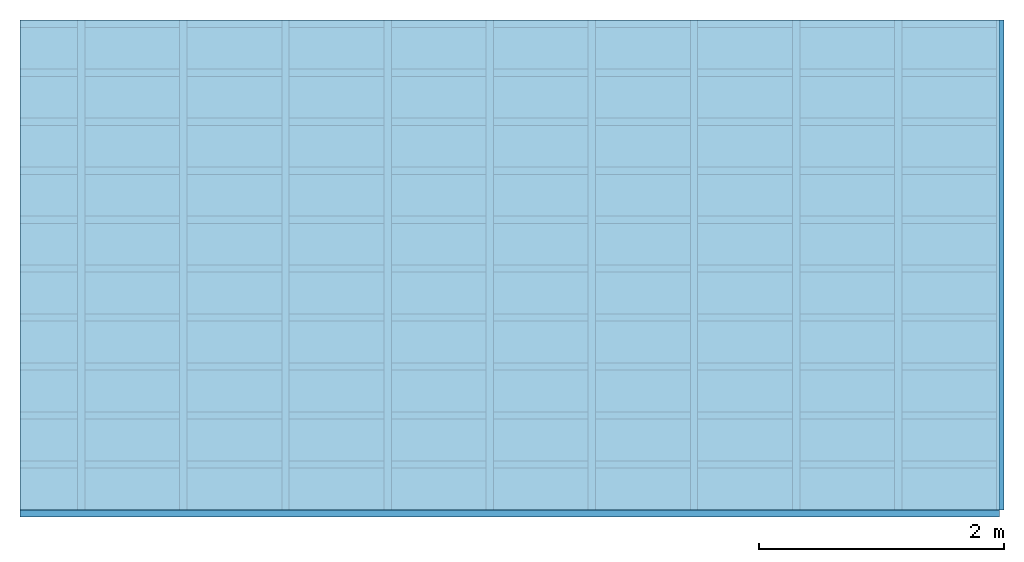
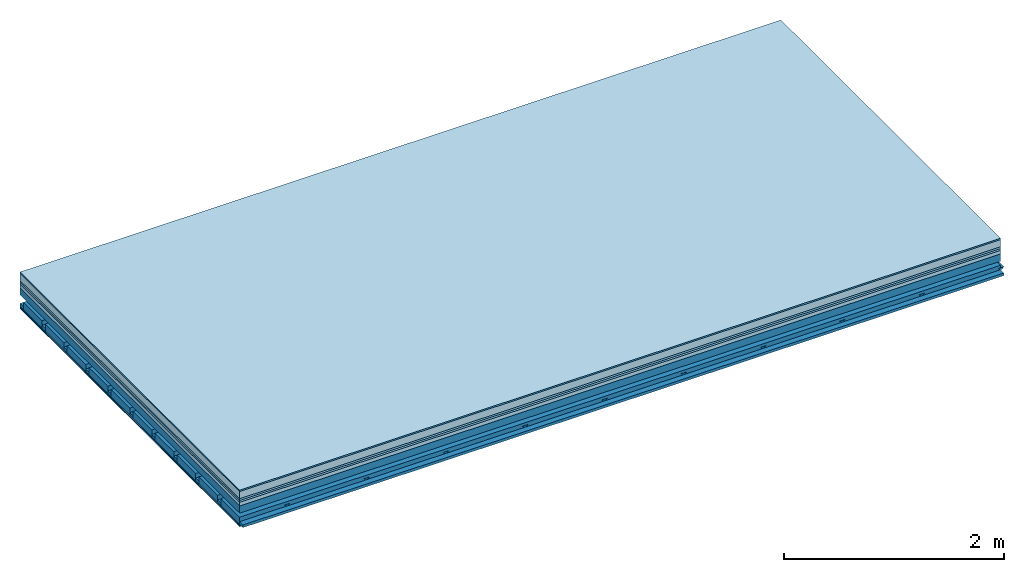
# One storey: 8 plates, 4 members, 1 element without a shape of its own.
"""IFC4 building model written with IfcOpenShell, lengths in metres."""

from ifc_helpers import new_model, si_unit, derived_unit, direction, frame, frame_2d, origin, origin_with_axes, place, context, project, spatial, polyline, rectangle, outline, extrude, material, layer, layer_set, type_object, element, aggregate, save


model = new_model("IFC4")

# Units and contexts
plan_context = context("Plan", 3, precision=1e-05, world=origin(), true_north=direction((0.0, 1.0)))
model_context = context("Model", 3, precision=1e-05, world=origin(), true_north=direction((0.0, 1.0)))
ifc_project = project(units=[si_unit("LENGTHUNIT", "METRE"), derived_unit("SOUNDPRESSUREUNIT", [(si_unit("PRESSUREUNIT", "PASCAL", prefix="MICRO"), 0)]), si_unit("ENERGYUNIT", "JOULE", prefix="MEGA"), si_unit("MASSUNIT", "GRAM", prefix="KILO"), derived_unit("THERMALTRANSMITTANCEUNIT", [(si_unit("POWERUNIT", "WATT"), 1), (si_unit("AREAUNIT", "SQUARE_METRE"), -1), (si_unit("THERMODYNAMICTEMPERATUREUNIT", "KELVIN"), -1)]), derived_unit("AREADENSITYUNIT", [(si_unit("MASSUNIT", "GRAM", prefix="KILO"), 1), (si_unit("AREAUNIT", "SQUARE_METRE"), -1)]), derived_unit("USERDEFINED", [(si_unit("ENERGYUNIT", "JOULE", prefix="MEGA"), 1), (si_unit("AREAUNIT", "SQUARE_METRE"), -1)])], contexts=[plan_context, model_context])

# Site, building, storey
site = spatial("IfcSite", under=ifc_project)
building_placement = place(None, origin())
building = spatial("IfcBuilding", under=site, at=building_placement)
storey_placement = place(building_placement, origin())
storey = spatial("IfcBuildingStorey", under=building, at=storey_placement)

# Slab, members, plates
ifc_material_1 = material(Category="11.013")
ifc_layer_1 = layer(ifc_material_1, 0.015, Name="Flooring")
ifc_material_2 = material(Name="Cement screed", Category="04.006")
ifc_layer_2 = layer(ifc_material_2, 0.08, Name="On-material")
ifc_material_3 = material(Name="Wood fiber generic product", Category="10.009")
ifc_layer_3 = layer(ifc_material_3, 0.02, Name="Impact sound insulation")
ifc_material_4 = material(Category="10.004")
ifc_layer_4 = layer(ifc_material_4, 0.02, Name="Additional insulation")
ifc_material_5 = material(Name="Garden plates", Category="02.007")
ifc_layer_5 = layer(ifc_material_5, 0.04, Name="on Supporting structure")
ifc_material_6 = material(Name="no composite action")
ifc_layer_6 = layer(ifc_material_6, 0.0, Name="Bond")
ifc_layer_7 = layer(None, 0.08, Name="Supporting structure")
ifc_layer_8 = layer(ifc_material_6, 0.0, Name="Bond")
ifc_layer_9 = layer(None, 0.095, Name="Coupling")
ifc_layer_10 = layer(None, 0.03, Name="Battens / profiles")
ifc_material_7 = material(Name="Plasterboard type A", Category="03.008")
ifc_layer_11 = layer(ifc_material_7, 0.0125, Name="Ceiling covering 1st layer")
ifc_layer_12 = layer(ifc_material_7, 0.0125, Name="Ceiling covering layer 2")
ifc_material_8 = material(Category="04.001")
ifc_layer_13 = layer(ifc_material_8, 0.003, Name="Surface / treatment")
ifc_layer_set = layer_set([ifc_layer_1, ifc_layer_2, ifc_layer_3, ifc_layer_4, ifc_layer_5, ifc_layer_6, ifc_layer_7, ifc_layer_8, ifc_layer_9, ifc_layer_10, ifc_layer_11, ifc_layer_12, ifc_layer_13])
slab_type = type_object("IfcSlabType", Name="A2166", PredefinedType="NOTDEFINED", material=ifc_layer_set)
slab_placement = place(None, frame((0.0, 0.0, 0.0), z_axis=(0.0, 0.0, -1.0), x_axis=(1.0, 0.0, 0.0)))
slab = element("IfcSlab", 1, at=slab_placement, inside=storey, type_object=slab_type, material=ifc_layer_set, Name="Slab #1")
ifc_material_9 = material(Name="Solid timber panel")
member_1_placement = place(slab_placement, origin())
member_1 = element("IfcMember", 2, at=member_1_placement, material=ifc_material_9, Name="Supporting structure", context=plan_context, shape_type="SweptSolid", body=[
    extrude(rectangle(XDim=1.0, YDim=0.08, at=frame_2d((0.5, 0.04), x_axis=(1.0, 0.0))), frame((0.0, 4.0, 0.175), z_axis=(0.0, -1.0, 0.0), x_axis=(1.0, 0.0, 0.0)), (0.0, 0.0, 1.0), 4.0),
    extrude(rectangle(XDim=1.0, YDim=0.08, at=frame_2d((0.5, 0.04), x_axis=(1.0, 0.0))), frame((1.0, 4.0, 0.175), z_axis=(0.0, -1.0, 0.0), x_axis=(1.0, 0.0, 0.0)), (0.0, 0.0, 1.0), 4.0),
    extrude(rectangle(XDim=1.0, YDim=0.08, at=frame_2d((0.5, 0.04), x_axis=(1.0, 0.0))), frame((2.0, 4.0, 0.175), z_axis=(0.0, -1.0, 0.0), x_axis=(1.0, 0.0, 0.0)), (0.0, 0.0, 1.0), 4.0),
    extrude(rectangle(XDim=1.0, YDim=0.08, at=frame_2d((0.5, 0.04), x_axis=(1.0, 0.0))), frame((3.0, 4.0, 0.175), z_axis=(0.0, -1.0, 0.0), x_axis=(1.0, 0.0, 0.0)), (0.0, 0.0, 1.0), 4.0),
    extrude(rectangle(XDim=1.0, YDim=0.08, at=frame_2d((0.5, 0.04), x_axis=(1.0, 0.0))), frame((4.0, 4.0, 0.175), z_axis=(0.0, -1.0, 0.0), x_axis=(1.0, 0.0, 0.0)), (0.0, 0.0, 1.0), 4.0),
    extrude(rectangle(XDim=1.0, YDim=0.08, at=frame_2d((0.5, 0.04), x_axis=(1.0, 0.0))), frame((5.0, 4.0, 0.175), z_axis=(0.0, -1.0, 0.0), x_axis=(1.0, 0.0, 0.0)), (0.0, 0.0, 1.0), 4.0),
    extrude(rectangle(XDim=1.0, YDim=0.08, at=frame_2d((0.5, 0.04), x_axis=(1.0, 0.0))), frame((6.0, 4.0, 0.175), z_axis=(0.0, -1.0, 0.0), x_axis=(1.0, 0.0, 0.0)), (0.0, 0.0, 1.0), 4.0),
    extrude(rectangle(XDim=1.0, YDim=0.08, at=frame_2d((0.5, 0.04), x_axis=(1.0, 0.0))), frame((7.0, 4.0, 0.175), z_axis=(0.0, -1.0, 0.0), x_axis=(1.0, 0.0, 0.0)), (0.0, 0.0, 1.0), 4.0),
])
ifc_material_10 = material()
member_2_placement = place(slab_placement, origin())
member_2 = element("IfcMember", 3, at=member_2_placement, material=ifc_material_10, Name="Coupling", context=plan_context, shape_type="SweptSolid", body=[
    extrude(outline(polyline([(0.0, 0.0), (0.06, 0.0), (0.04, 0.02), (0.02, 0.02), (0.0, 0.0)])), frame((0.47, 4.0, 0.33), z_axis=(0.0, -1.0, 0.0), x_axis=(1.0, 0.0, 0.0)), (0.0, 0.0, 1.0), 4.0),
    extrude(outline(polyline([(0.0, 0.0), (0.06, 0.0), (0.04, 0.02), (0.02, 0.02), (0.0, 0.0)])), frame((1.304, 4.0, 0.33), z_axis=(0.0, -1.0, 0.0), x_axis=(1.0, 0.0, 0.0)), (0.0, 0.0, 1.0), 4.0),
    extrude(outline(polyline([(0.0, 0.0), (0.06, 0.0), (0.04, 0.02), (0.02, 0.02), (0.0, 0.0)])), frame((2.138, 4.0, 0.33), z_axis=(0.0, -1.0, 0.0), x_axis=(1.0, 0.0, 0.0)), (0.0, 0.0, 1.0), 4.0),
    extrude(outline(polyline([(0.0, 0.0), (0.06, 0.0), (0.04, 0.02), (0.02, 0.02), (0.0, 0.0)])), frame((2.972, 4.0, 0.33), z_axis=(0.0, -1.0, 0.0), x_axis=(1.0, 0.0, 0.0)), (0.0, 0.0, 1.0), 4.0),
    extrude(outline(polyline([(0.0, 0.0), (0.06, 0.0), (0.04, 0.02), (0.02, 0.02), (0.0, 0.0)])), frame((3.806, 4.0, 0.33), z_axis=(0.0, -1.0, 0.0), x_axis=(1.0, 0.0, 0.0)), (0.0, 0.0, 1.0), 4.0),
    extrude(outline(polyline([(0.0, 0.0), (0.06, 0.0), (0.04, 0.02), (0.02, 0.02), (0.0, 0.0)])), frame((4.64, 4.0, 0.33), z_axis=(0.0, -1.0, 0.0), x_axis=(1.0, 0.0, 0.0)), (0.0, 0.0, 1.0), 4.0),
    extrude(outline(polyline([(0.0, 0.0), (0.06, 0.0), (0.04, 0.02), (0.02, 0.02), (0.0, 0.0)])), frame((5.474, 4.0, 0.33), z_axis=(0.0, -1.0, 0.0), x_axis=(1.0, 0.0, 0.0)), (0.0, 0.0, 1.0), 4.0),
    extrude(outline(polyline([(0.0, 0.0), (0.06, 0.0), (0.04, 0.02), (0.02, 0.02), (0.0, 0.0)])), frame((6.308, 4.0, 0.33), z_axis=(0.0, -1.0, 0.0), x_axis=(1.0, 0.0, 0.0)), (0.0, 0.0, 1.0), 4.0),
    extrude(outline(polyline([(0.0, 0.0), (0.06, 0.0), (0.04, 0.02), (0.02, 0.02), (0.0, 0.0)])), frame((7.142, 4.0, 0.33), z_axis=(0.0, -1.0, 0.0), x_axis=(1.0, 0.0, 0.0)), (0.0, 0.0, 1.0), 4.0),
    extrude(outline(polyline([(0.0, 0.0), (0.06, 0.0), (0.04, 0.02), (0.02, 0.02), (0.0, 0.0)])), frame((7.976, 4.0, 0.33), z_axis=(0.0, -1.0, 0.0), x_axis=(1.0, 0.0, 0.0)), (0.0, 0.0, 1.0), 4.0),
])
member_3_placement = place(slab_placement, origin())
member_3 = element("IfcMember", 4, at=member_3_placement, material=ifc_material_10, Name="Battens / profiles", context=plan_context, shape_type="SweptSolid", body=[
    extrude(rectangle(XDim=0.06, YDim=0.03, at=frame_2d((0.03, 0.015), x_axis=(1.0, 0.0))), frame((0.0, 0.0, 0.35), z_axis=(1.0, 0.0, 0.0), x_axis=(0.0, 1.0, 0.0)), (0.0, 0.0, 1.0), 8.0),
    extrude(rectangle(XDim=0.06, YDim=0.03, at=frame_2d((0.03, 0.015), x_axis=(1.0, 0.0))), frame((0.0, 0.4, 0.35), z_axis=(1.0, 0.0, 0.0), x_axis=(0.0, 1.0, 0.0)), (0.0, 0.0, 1.0), 8.0),
    extrude(rectangle(XDim=0.06, YDim=0.03, at=frame_2d((0.03, 0.015), x_axis=(1.0, 0.0))), frame((0.0, 0.8, 0.35), z_axis=(1.0, 0.0, 0.0), x_axis=(0.0, 1.0, 0.0)), (0.0, 0.0, 1.0), 8.0),
    extrude(rectangle(XDim=0.06, YDim=0.03, at=frame_2d((0.03, 0.015), x_axis=(1.0, 0.0))), frame((0.0, 1.2, 0.35), z_axis=(1.0, 0.0, 0.0), x_axis=(0.0, 1.0, 0.0)), (0.0, 0.0, 1.0), 8.0),
    extrude(rectangle(XDim=0.06, YDim=0.03, at=frame_2d((0.03, 0.015), x_axis=(1.0, 0.0))), frame((0.0, 1.6, 0.35), z_axis=(1.0, 0.0, 0.0), x_axis=(0.0, 1.0, 0.0)), (0.0, 0.0, 1.0), 8.0),
    extrude(rectangle(XDim=0.06, YDim=0.03, at=frame_2d((0.03, 0.015), x_axis=(1.0, 0.0))), frame((0.0, 2.0, 0.35), z_axis=(1.0, 0.0, 0.0), x_axis=(0.0, 1.0, 0.0)), (0.0, 0.0, 1.0), 8.0),
    extrude(rectangle(XDim=0.06, YDim=0.03, at=frame_2d((0.03, 0.015), x_axis=(1.0, 0.0))), frame((0.0, 2.4, 0.35), z_axis=(1.0, 0.0, 0.0), x_axis=(0.0, 1.0, 0.0)), (0.0, 0.0, 1.0), 8.0),
    extrude(rectangle(XDim=0.06, YDim=0.03, at=frame_2d((0.03, 0.015), x_axis=(1.0, 0.0))), frame((0.0, 2.8, 0.35), z_axis=(1.0, 0.0, 0.0), x_axis=(0.0, 1.0, 0.0)), (0.0, 0.0, 1.0), 8.0),
    extrude(rectangle(XDim=0.06, YDim=0.03, at=frame_2d((0.03, 0.015), x_axis=(1.0, 0.0))), frame((0.0, 3.2, 0.35), z_axis=(1.0, 0.0, 0.0), x_axis=(0.0, 1.0, 0.0)), (0.0, 0.0, 1.0), 8.0),
    extrude(rectangle(XDim=0.06, YDim=0.03, at=frame_2d((0.03, 0.015), x_axis=(1.0, 0.0))), frame((0.0, 3.6, 0.35), z_axis=(1.0, 0.0, 0.0), x_axis=(0.0, 1.0, 0.0)), (0.0, 0.0, 1.0), 8.0),
    extrude(rectangle(XDim=0.06, YDim=0.03, at=frame_2d((0.03, 0.015), x_axis=(1.0, 0.0))), frame((0.0, 4.0, 0.35), z_axis=(1.0, 0.0, 0.0), x_axis=(0.0, 1.0, 0.0)), (0.0, 0.0, 1.0), 8.0),
])
ifc_material_11 = material()
member_4_placement = place(slab_placement, origin())
member_4 = element("IfcMember", 5, at=member_4_placement, material=ifc_material_11, Name="Cavity", context=plan_context, shape_type="SweptSolid", body=[
    extrude(rectangle(XDim=0.34, YDim=0.08, at=frame_2d((0.17, 0.04), x_axis=(1.0, 0.0))), frame((0.0, 0.06, 0.3), z_axis=(1.0, 0.0, 0.0), x_axis=(0.0, 1.0, 0.0)), (0.0, 0.0, 1.0), 8.0),
    extrude(rectangle(XDim=0.34, YDim=0.08, at=frame_2d((0.17, 0.04), x_axis=(1.0, 0.0))), frame((0.0, 0.46, 0.3), z_axis=(1.0, 0.0, 0.0), x_axis=(0.0, 1.0, 0.0)), (0.0, 0.0, 1.0), 8.0),
    extrude(rectangle(XDim=0.34, YDim=0.08, at=frame_2d((0.17, 0.04), x_axis=(1.0, 0.0))), frame((0.0, 0.86, 0.3), z_axis=(1.0, 0.0, 0.0), x_axis=(0.0, 1.0, 0.0)), (0.0, 0.0, 1.0), 8.0),
    extrude(rectangle(XDim=0.34, YDim=0.08, at=frame_2d((0.17, 0.04), x_axis=(1.0, 0.0))), frame((0.0, 1.26, 0.3), z_axis=(1.0, 0.0, 0.0), x_axis=(0.0, 1.0, 0.0)), (0.0, 0.0, 1.0), 8.0),
    extrude(rectangle(XDim=0.34, YDim=0.08, at=frame_2d((0.17, 0.04), x_axis=(1.0, 0.0))), frame((0.0, 1.66, 0.3), z_axis=(1.0, 0.0, 0.0), x_axis=(0.0, 1.0, 0.0)), (0.0, 0.0, 1.0), 8.0),
    extrude(rectangle(XDim=0.34, YDim=0.08, at=frame_2d((0.17, 0.04), x_axis=(1.0, 0.0))), frame((0.0, 2.06, 0.3), z_axis=(1.0, 0.0, 0.0), x_axis=(0.0, 1.0, 0.0)), (0.0, 0.0, 1.0), 8.0),
    extrude(rectangle(XDim=0.34, YDim=0.08, at=frame_2d((0.17, 0.04), x_axis=(1.0, 0.0))), frame((0.0, 2.46, 0.3), z_axis=(1.0, 0.0, 0.0), x_axis=(0.0, 1.0, 0.0)), (0.0, 0.0, 1.0), 8.0),
    extrude(rectangle(XDim=0.34, YDim=0.08, at=frame_2d((0.17, 0.04), x_axis=(1.0, 0.0))), frame((0.0, 2.86, 0.3), z_axis=(1.0, 0.0, 0.0), x_axis=(0.0, 1.0, 0.0)), (0.0, 0.0, 1.0), 8.0),
    extrude(rectangle(XDim=0.34, YDim=0.08, at=frame_2d((0.17, 0.04), x_axis=(1.0, 0.0))), frame((0.0, 3.26, 0.3), z_axis=(1.0, 0.0, 0.0), x_axis=(0.0, 1.0, 0.0)), (0.0, 0.0, 1.0), 8.0),
    extrude(rectangle(XDim=0.34, YDim=0.08, at=frame_2d((0.17, 0.04), x_axis=(1.0, 0.0))), frame((0.0, 3.66, 0.3), z_axis=(1.0, 0.0, 0.0), x_axis=(0.0, 1.0, 0.0)), (0.0, 0.0, 1.0), 8.0),
])
plate_1_placement = place(slab_placement, origin())
plate_1 = element("IfcPlate", 6, at=plate_1_placement, material=ifc_material_1, Name="Flooring", context=plan_context, shape_type="SweptSolid", body=[
    extrude(rectangle(XDim=8.0, YDim=4.0, at=frame_2d((4.0, 2.0), x_axis=(1.0, 0.0))), origin_with_axes(), (0.0, 0.0, 1.0), 0.015),
])
plate_2_placement = place(slab_placement, origin())
plate_2 = element("IfcPlate", 7, at=plate_2_placement, material=ifc_material_2, Name="On-material", context=plan_context, shape_type="SweptSolid", body=[
    extrude(rectangle(XDim=8.0, YDim=4.0, at=frame_2d((4.0, 2.0), x_axis=(1.0, 0.0))), frame((0.0, 0.0, 0.015), z_axis=(0.0, 0.0, 1.0), x_axis=(1.0, 0.0, 0.0)), (0.0, 0.0, 1.0), 0.08),
])
plate_3_placement = place(slab_placement, origin())
plate_3 = element("IfcPlate", 8, at=plate_3_placement, material=ifc_material_3, Name="Impact sound insulation", context=plan_context, shape_type="SweptSolid", body=[
    extrude(rectangle(XDim=8.0, YDim=4.0, at=frame_2d((4.0, 2.0), x_axis=(1.0, 0.0))), frame((0.0, 0.0, 0.095), z_axis=(0.0, 0.0, 1.0), x_axis=(1.0, 0.0, 0.0)), (0.0, 0.0, 1.0), 0.02),
])
plate_4_placement = place(slab_placement, origin())
plate_4 = element("IfcPlate", 9, at=plate_4_placement, material=ifc_material_4, Name="Additional insulation", context=plan_context, shape_type="SweptSolid", body=[
    extrude(rectangle(XDim=8.0, YDim=4.0, at=frame_2d((4.0, 2.0), x_axis=(1.0, 0.0))), frame((0.0, 0.0, 0.115), z_axis=(0.0, 0.0, 1.0), x_axis=(1.0, 0.0, 0.0)), (0.0, 0.0, 1.0), 0.02),
])
plate_5_placement = place(slab_placement, origin())
plate_5 = element("IfcPlate", 10, at=plate_5_placement, material=ifc_material_5, Name="on Supporting structure", context=plan_context, shape_type="SweptSolid", body=[
    extrude(rectangle(XDim=8.0, YDim=4.0, at=frame_2d((4.0, 2.0), x_axis=(1.0, 0.0))), frame((0.0, 0.0, 0.135), z_axis=(0.0, 0.0, 1.0), x_axis=(1.0, 0.0, 0.0)), (0.0, 0.0, 1.0), 0.04),
])
plate_6_placement = place(slab_placement, origin())
plate_6 = element("IfcPlate", 11, at=plate_6_placement, material=ifc_material_7, Name="Ceiling covering 1st layer", context=plan_context, shape_type="SweptSolid", body=[
    extrude(rectangle(XDim=8.0, YDim=4.0, at=frame_2d((4.0, 2.0), x_axis=(1.0, 0.0))), frame((0.0, 0.0, 0.38), z_axis=(0.0, 0.0, 1.0), x_axis=(1.0, 0.0, 0.0)), (0.0, 0.0, 1.0), 0.0125),
])
plate_7_placement = place(slab_placement, origin())
plate_7 = element("IfcPlate", 12, at=plate_7_placement, material=ifc_material_7, Name="Ceiling covering layer 2", context=plan_context, shape_type="SweptSolid", body=[
    extrude(rectangle(XDim=8.0, YDim=4.0, at=frame_2d((4.0, 2.0), x_axis=(1.0, 0.0))), frame((0.0, 0.0, 0.3925), z_axis=(0.0, 0.0, 1.0), x_axis=(1.0, 0.0, 0.0)), (0.0, 0.0, 1.0), 0.0125),
])
plate_8_placement = place(slab_placement, origin())
plate_8 = element("IfcPlate", 13, at=plate_8_placement, material=ifc_material_8, Name="Surface / treatment", context=plan_context, shape_type="SweptSolid", body=[
    extrude(rectangle(XDim=8.0, YDim=4.0, at=frame_2d((4.0, 2.0), x_axis=(1.0, 0.0))), frame((0.0, 0.0, 0.405), z_axis=(0.0, 0.0, 1.0), x_axis=(1.0, 0.0, 0.0)), (0.0, 0.0, 1.0), 0.003),
])
aggregate(slab, [plate_1, plate_2, plate_3, plate_4, plate_5, member_1, member_2, member_3, member_4, plate_6, plate_7, plate_8])

save(model, "model.ifc")
